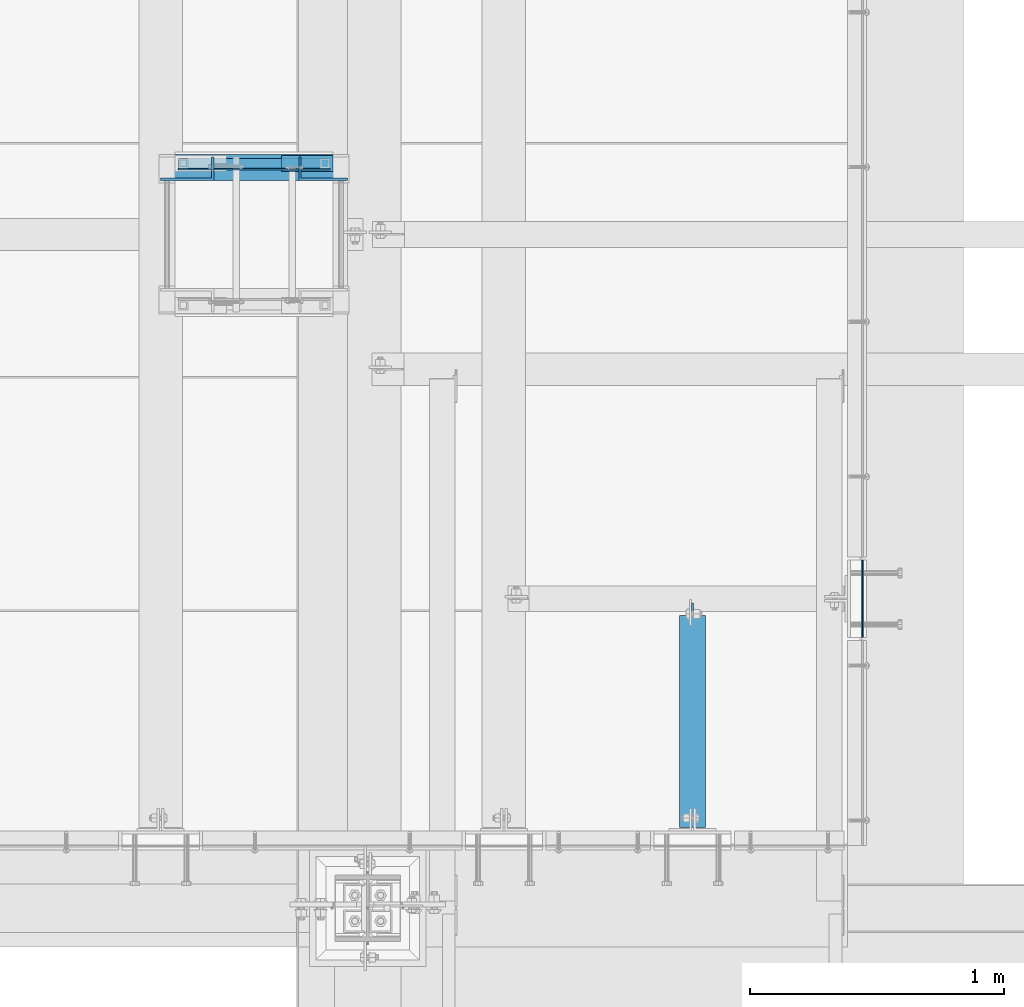
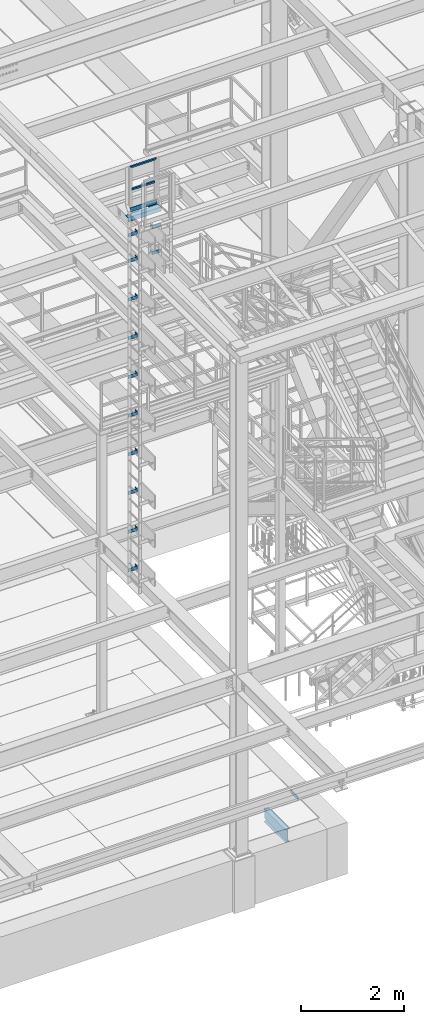
# One storey, part 2058 of 3843: 19 beams, 6 elements without a shape of their own.
"""IFC2X3 building model written with IfcOpenShell, lengths in millimetres."""

from ifc_helpers import new_model, si_unit, frame, origin_with_axes, place, context, subcontext, project, spatial, faceted_brep, material, type_object, element, aggregate, save


model = new_model("IFC2X3")

# Units and contexts
model_context = context("Model", 3, precision=1e-05, world=origin_with_axes())
body_context = subcontext(model_context, "Body", "Model", "MODEL_VIEW")
ifc_project = project(units=[si_unit("LENGTHUNIT", "METRE", prefix="MILLI"), si_unit("AREAUNIT", "SQUARE_METRE"), si_unit("VOLUMEUNIT", "CUBIC_METRE"), si_unit("MASSUNIT", "GRAM", prefix="KILO"), si_unit("TIMEUNIT", "SECOND"), si_unit("PLANEANGLEUNIT", "RADIAN"), si_unit("SOLIDANGLEUNIT", "STERADIAN"), si_unit("THERMODYNAMICTEMPERATUREUNIT", "DEGREE_CELSIUS"), si_unit("LUMINOUSINTENSITYUNIT", "LUMEN")], contexts=[model_context])

# Site, building, storey
site_placement = place(None, origin_with_axes())
site = spatial("IfcSite", under=ifc_project, at=site_placement, CompositionType="ELEMENT")
building_placement = place(site_placement, origin_with_axes())
building = spatial("IfcBuilding", under=site, at=building_placement, Name="Undefined", CompositionType="ELEMENT")
storey_placement = place(building_placement, origin_with_axes())
storey = spatial("IfcBuildingStorey", under=building, at=storey_placement, Name="Undefined", CompositionType="ELEMENT", Elevation=0.0)

# Assembly, beams
assembly_1_placement = place(storey_placement, origin_with_axes())
assembly_1 = element("IfcElementAssembly", 1, at=assembly_1_placement, inside=storey, Name="LADDER", AssemblyPlace="NOTDEFINED", PredefinedType="RIGID_FRAME")
ifc_material_1 = material(Name="STEEL/A36")
beam_type_1 = type_object("IfcBeamType", PredefinedType="NOTDEFINED")
beam_1_placement = place(assembly_1_placement, frame((48917.225012207, 17870.4875, 43021.25), z_axis=(0.0, 0.0, 1.0), x_axis=(-1.0, 0.0, 0.0)))
beam_1 = element("IfcBeam", 2, at=beam_1_placement, type_object=beam_type_1, material=ifc_material_1, Name="BENT_PLATE", context=body_context, shape_type="Brep", body=[
    faceted_brep([(0.0, -4.76250000000073, -38.0999999999985), (0.0, -4.76250000000073, 38.0999999999985), (0.0, 4.76250000000073, 38.0999999999985), (0.0, 4.76250000000073, -38.0999999999985), (192.087500000001, 4.76249999999345, 38.0999999999985), (192.087500000001, 4.76249999999345, -38.0999999999985), (182.562500000007, -4.762500000008, -38.0999999999985), (182.562500000007, -4.762500000008, 38.0999999999985), (192.087500000001, -87.3124999995016, 38.0999999999985), (192.087500000001, -87.3124999995016, -38.0999999999985), (182.562500000007, -87.3124999995016, 38.0999999999985), (182.562500000007, -87.3124999995016, -38.0999999999985)], [[[0, 1, 2, 3]], [[3, 2, 4, 5]], [[1, 0, 6, 7]], [[5, 4, 8, 9]], [[4, 2, 1, 7, 10, 8]], [[7, 6, 11, 10]], [[6, 0, 3, 5, 9, 11]], [[10, 11, 9, 8]]]),
])
beam_2_placement = place(assembly_1_placement, frame((48917.225012207, 17870.4875, 43630.85), z_axis=(0.0, 0.0, 1.0), x_axis=(-1.0, 0.0, 0.0)))
beam_2 = element("IfcBeam", 3, at=beam_2_placement, type_object=beam_type_1, material=ifc_material_1, Name="BENT_PLATE", context=body_context, shape_type="Brep", body=[
    faceted_brep([(0.0, -4.76250000000073, -38.0999999999985), (0.0, -4.76250000000073, 38.0999999999985), (0.0, 4.76250000000073, 38.0999999999985), (0.0, 4.76250000000073, -38.0999999999985), (192.087500000001, 4.76249999999345, 38.0999999999985), (192.087500000001, 4.76249999999345, -38.0999999999985), (182.562500000007, -4.762500000008, -38.0999999999985), (182.562500000007, -4.762500000008, 38.0999999999985), (192.087500000001, -87.3124999995016, 38.0999999999985), (192.087500000001, -87.3124999995016, -38.0999999999985), (182.562500000007, -87.3124999995016, 38.0999999999985), (182.562500000007, -87.3124999995016, -38.0999999999985)], [[[0, 1, 2, 3]], [[3, 2, 4, 5]], [[1, 0, 6, 7]], [[5, 4, 8, 9]], [[4, 2, 1, 7, 10, 8]], [[7, 6, 11, 10]], [[6, 0, 3, 5, 9, 11]], [[10, 11, 9, 8]]]),
])
aggregate(assembly_1, [beam_1, beam_2])

assembly_2_placement = place(storey_placement, origin_with_axes())
assembly_2 = element("IfcElementAssembly", 4, at=assembly_2_placement, inside=storey, Name="LADDER", AssemblyPlace="NOTDEFINED", PredefinedType="RIGID_FRAME")
beam_3_placement = place(assembly_2_placement, frame((48180.624987793, 17870.4875, 43630.85), z_axis=(0.0, 0.0, 1.0), x_axis=(1.0, 0.0, 0.0)))
beam_3 = element("IfcBeam", 5, at=beam_3_placement, type_object=beam_type_1, material=ifc_material_1, Name="BENT_PLATE", context=body_context, shape_type="Brep", body=[
    faceted_brep([(0.0, -4.76250000000073, -38.0999999999985), (0.0, -4.76250000000073, 38.0999999999985), (0.0, 4.76250000000073, 38.0999999999985), (0.0, 4.76250000000073, -38.0999999999985), (200.025000000009, 4.762500000008, 38.0999999999985), (200.025000000009, 4.762500000008, -38.0999999999985), (209.550000000003, -4.76249999999345, -38.0999999999985), (209.550000000003, -4.76249999999345, 38.0999999999985), (200.025000000009, 87.3124999995016, 38.0999999999985), (200.025000000009, 87.3124999995016, -38.0999999999985), (209.550000000003, 87.3124999995016, 38.0999999999985), (209.550000000003, 87.3124999995016, -38.0999999999985)], [[[0, 1, 2, 3]], [[3, 2, 4, 5]], [[1, 0, 6, 7]], [[5, 4, 8, 9]], [[4, 2, 1, 7, 10, 8]], [[7, 6, 11, 10]], [[6, 0, 3, 5, 9, 11]], [[10, 11, 9, 8]]]),
])
beam_4_placement = place(assembly_2_placement, frame((48180.624987793, 17870.4875, 43021.25), z_axis=(0.0, 0.0, 1.0), x_axis=(1.0, 0.0, 0.0)))
beam_4 = element("IfcBeam", 6, at=beam_4_placement, type_object=beam_type_1, material=ifc_material_1, Name="BENT_PLATE", context=body_context, shape_type="Brep", body=[
    faceted_brep([(0.0, -4.76250000000073, -38.0999999999985), (0.0, -4.76250000000073, 38.0999999999985), (0.0, 4.76250000000073, 38.0999999999985), (0.0, 4.76250000000073, -38.0999999999985), (200.025000000009, 4.762500000008, 38.0999999999985), (200.025000000009, 4.762500000008, -38.0999999999985), (209.550000000003, -4.76249999999345, -38.0999999999985), (209.550000000003, -4.76249999999345, 38.0999999999985), (200.025000000009, 87.3124999995016, 38.0999999999985), (200.025000000009, 87.3124999995016, -38.0999999999985), (209.550000000003, 87.3124999995016, 38.0999999999985), (209.550000000003, 87.3124999995016, -38.0999999999985)], [[[0, 1, 2, 3]], [[3, 2, 4, 5]], [[1, 0, 6, 7]], [[5, 4, 8, 9]], [[4, 2, 1, 7, 10, 8]], [[7, 6, 11, 10]], [[6, 0, 3, 5, 9, 11]], [[10, 11, 9, 8]]]),
])
beam_5_placement = place(assembly_2_placement, frame((48180.624987793, 17870.4875, 42106.85), z_axis=(0.0, 0.0, 1.0), x_axis=(1.0, 0.0, 0.0)))
beam_5 = element("IfcBeam", 7, at=beam_5_placement, type_object=beam_type_1, material=ifc_material_1, Name="BENT_PLATE", context=body_context, shape_type="Brep", body=[
    faceted_brep([(0.0, -4.76250000000073, -38.0999999999985), (0.0, -4.76250000000073, 38.0999999999985), (0.0, 4.76250000000073, 38.0999999999985), (0.0, 4.76250000000073, -38.0999999999985), (200.025000000009, 4.762500000008, 38.0999999999985), (200.025000000009, 4.762500000008, -38.0999999999985), (209.550000000003, -4.76249999999345, -38.0999999999985), (209.550000000003, -4.76249999999345, 38.0999999999985), (200.025000000009, 87.3124999995016, 38.0999999999985), (200.025000000009, 87.3124999995016, -38.0999999999985), (209.550000000003, 87.3124999995016, 38.0999999999985), (209.550000000003, 87.3124999995016, -38.0999999999985)], [[[0, 1, 2, 3]], [[3, 2, 4, 5]], [[1, 0, 6, 7]], [[5, 4, 8, 9]], [[4, 2, 1, 7, 10, 8]], [[7, 6, 11, 10]], [[6, 0, 3, 5, 9, 11]], [[10, 11, 9, 8]]]),
])
beam_6_placement = place(assembly_2_placement, frame((48180.624987793, 17870.4875, 41192.45), z_axis=(0.0, 0.0, 1.0), x_axis=(1.0, 0.0, 0.0)))
beam_6 = element("IfcBeam", 8, at=beam_6_placement, type_object=beam_type_1, material=ifc_material_1, Name="BENT_PLATE", context=body_context, shape_type="Brep", body=[
    faceted_brep([(0.0, -4.76250000000073, -38.0999999999985), (0.0, -4.76250000000073, 38.0999999999985), (0.0, 4.76250000000073, 38.0999999999985), (0.0, 4.76250000000073, -38.0999999999985), (200.025000000009, 4.762500000008, 38.0999999999985), (200.025000000009, 4.762500000008, -38.0999999999985), (209.550000000003, -4.76249999999345, -38.0999999999985), (209.550000000003, -4.76249999999345, 38.0999999999985), (200.025000000009, 87.3124999995016, 38.0999999999985), (200.025000000009, 87.3124999995016, -38.0999999999985), (209.550000000003, 87.3124999995016, 38.0999999999985), (209.550000000003, 87.3124999995016, -38.0999999999985)], [[[0, 1, 2, 3]], [[3, 2, 4, 5]], [[1, 0, 6, 7]], [[5, 4, 8, 9]], [[4, 2, 1, 7, 10, 8]], [[7, 6, 11, 10]], [[6, 0, 3, 5, 9, 11]], [[10, 11, 9, 8]]]),
])
beam_7_placement = place(assembly_2_placement, frame((48180.624987793, 17870.4875, 40278.05), z_axis=(0.0, 0.0, 1.0), x_axis=(1.0, 0.0, 0.0)))
beam_7 = element("IfcBeam", 9, at=beam_7_placement, type_object=beam_type_1, material=ifc_material_1, Name="BENT_PLATE", context=body_context, shape_type="Brep", body=[
    faceted_brep([(0.0, -4.76250000000073, -38.0999999999985), (0.0, -4.76250000000073, 38.0999999999985), (0.0, 4.76250000000073, 38.0999999999985), (0.0, 4.76250000000073, -38.0999999999985), (200.025000000009, 4.762500000008, 38.0999999999985), (200.025000000009, 4.762500000008, -38.0999999999985), (209.550000000003, -4.76249999999345, -38.0999999999985), (209.550000000003, -4.76249999999345, 38.0999999999985), (200.025000000009, 87.3124999995016, 38.0999999999985), (200.025000000009, 87.3124999995016, -38.0999999999985), (209.550000000003, 87.3124999995016, 38.0999999999985), (209.550000000003, 87.3124999995016, -38.0999999999985)], [[[0, 1, 2, 3]], [[3, 2, 4, 5]], [[1, 0, 6, 7]], [[5, 4, 8, 9]], [[4, 2, 1, 7, 10, 8]], [[7, 6, 11, 10]], [[6, 0, 3, 5, 9, 11]], [[10, 11, 9, 8]]]),
])
beam_8_placement = place(assembly_2_placement, frame((48180.624987793, 17870.4875, 39363.65), z_axis=(0.0, 0.0, 1.0), x_axis=(1.0, 0.0, 0.0)))
beam_8 = element("IfcBeam", 10, at=beam_8_placement, type_object=beam_type_1, material=ifc_material_1, Name="BENT_PLATE", context=body_context, shape_type="Brep", body=[
    faceted_brep([(0.0, -4.76250000000073, -38.0999999999985), (0.0, -4.76250000000073, 38.0999999999985), (0.0, 4.76250000000073, 38.0999999999985), (0.0, 4.76250000000073, -38.0999999999985), (200.025000000009, 4.762500000008, 38.0999999999985), (200.025000000009, 4.762500000008, -38.0999999999985), (209.550000000003, -4.76249999999345, -38.0999999999985), (209.550000000003, -4.76249999999345, 38.0999999999985), (200.025000000009, 87.3124999995016, 38.0999999999985), (200.025000000009, 87.3124999995016, -38.0999999999985), (209.550000000003, 87.3124999995016, 38.0999999999985), (209.550000000003, 87.3124999995016, -38.0999999999985)], [[[0, 1, 2, 3]], [[3, 2, 4, 5]], [[1, 0, 6, 7]], [[5, 4, 8, 9]], [[4, 2, 1, 7, 10, 8]], [[7, 6, 11, 10]], [[6, 0, 3, 5, 9, 11]], [[10, 11, 9, 8]]]),
])
beam_9_placement = place(assembly_2_placement, frame((48180.624987793, 17870.4875, 38449.25), z_axis=(0.0, 0.0, 1.0), x_axis=(1.0, 0.0, 0.0)))
beam_9 = element("IfcBeam", 11, at=beam_9_placement, type_object=beam_type_1, material=ifc_material_1, Name="BENT_PLATE", context=body_context, shape_type="Brep", body=[
    faceted_brep([(0.0, -4.76250000000073, -38.0999999999985), (0.0, -4.76250000000073, 38.0999999999985), (0.0, 4.76250000000073, 38.0999999999985), (0.0, 4.76250000000073, -38.0999999999985), (200.025000000009, 4.762500000008, 38.0999999999985), (200.025000000009, 4.762500000008, -38.0999999999985), (209.550000000003, -4.76249999999345, -38.0999999999985), (209.550000000003, -4.76249999999345, 38.0999999999985), (200.025000000009, 87.3124999995016, 38.0999999999985), (200.025000000009, 87.3124999995016, -38.0999999999985), (209.550000000003, 87.3124999995016, 38.0999999999985), (209.550000000003, 87.3124999995016, -38.0999999999985)], [[[0, 1, 2, 3]], [[3, 2, 4, 5]], [[1, 0, 6, 7]], [[5, 4, 8, 9]], [[4, 2, 1, 7, 10, 8]], [[7, 6, 11, 10]], [[6, 0, 3, 5, 9, 11]], [[10, 11, 9, 8]]]),
])
beam_10_placement = place(assembly_2_placement, frame((48180.624987793, 17870.4875, 37534.85), z_axis=(0.0, 0.0, 1.0), x_axis=(1.0, 0.0, 0.0)))
beam_10 = element("IfcBeam", 12, at=beam_10_placement, type_object=beam_type_1, material=ifc_material_1, Name="BENT_PLATE", context=body_context, shape_type="Brep", body=[
    faceted_brep([(0.0, -4.76250000000073, -38.0999999999985), (0.0, -4.76250000000073, 38.0999999999985), (0.0, 4.76250000000073, 38.0999999999985), (0.0, 4.76250000000073, -38.0999999999985), (200.025000000009, 4.762500000008, 38.0999999999985), (200.025000000009, 4.762500000008, -38.0999999999985), (209.550000000003, -4.76249999999345, -38.0999999999985), (209.550000000003, -4.76249999999345, 38.0999999999985), (200.025000000009, 87.3124999995016, 38.0999999999985), (200.025000000009, 87.3124999995016, -38.0999999999985), (209.550000000003, 87.3124999995016, 38.0999999999985), (209.550000000003, 87.3124999995016, -38.0999999999985)], [[[0, 1, 2, 3]], [[3, 2, 4, 5]], [[1, 0, 6, 7]], [[5, 4, 8, 9]], [[4, 2, 1, 7, 10, 8]], [[7, 6, 11, 10]], [[6, 0, 3, 5, 9, 11]], [[10, 11, 9, 8]]]),
])
beam_11_placement = place(assembly_2_placement, frame((48180.624987793, 17870.4875, 36620.45), z_axis=(0.0, 0.0, 1.0), x_axis=(1.0, 0.0, 0.0)))
beam_11 = element("IfcBeam", 13, at=beam_11_placement, type_object=beam_type_1, material=ifc_material_1, Name="BENT_PLATE", context=body_context, shape_type="Brep", body=[
    faceted_brep([(0.0, -4.76250000000073, -38.0999999999985), (0.0, -4.76250000000073, 38.0999999999985), (0.0, 4.76250000000073, 38.0999999999985), (0.0, 4.76250000000073, -38.0999999999985), (200.025000000009, 4.762500000008, 38.0999999999985), (200.025000000009, 4.762500000008, -38.0999999999985), (209.550000000003, -4.76249999999345, -38.0999999999985), (209.550000000003, -4.76249999999345, 38.0999999999985), (200.025000000009, 87.3124999995016, 38.0999999999985), (200.025000000009, 87.3124999995016, -38.0999999999985), (209.550000000003, 87.3124999995016, 38.0999999999985), (209.550000000003, 87.3124999995016, -38.0999999999985)], [[[0, 1, 2, 3]], [[3, 2, 4, 5]], [[1, 0, 6, 7]], [[5, 4, 8, 9]], [[4, 2, 1, 7, 10, 8]], [[7, 6, 11, 10]], [[6, 0, 3, 5, 9, 11]], [[10, 11, 9, 8]]]),
])
beam_12_placement = place(assembly_2_placement, frame((48180.624987793, 17870.4875, 35706.05), z_axis=(0.0, 0.0, 1.0), x_axis=(1.0, 0.0, 0.0)))
beam_12 = element("IfcBeam", 14, at=beam_12_placement, type_object=beam_type_1, material=ifc_material_1, Name="BENT_PLATE", context=body_context, shape_type="Brep", body=[
    faceted_brep([(0.0, -4.76250000000073, -38.0999999999985), (0.0, -4.76250000000073, 38.0999999999985), (0.0, 4.76250000000073, 38.0999999999985), (0.0, 4.76250000000073, -38.0999999999985), (200.025000000009, 4.762500000008, 38.0999999999985), (200.025000000009, 4.762500000008, -38.0999999999985), (209.550000000003, -4.76249999999345, -38.0999999999985), (209.550000000003, -4.76249999999345, 38.0999999999985), (200.025000000009, 87.3124999995016, 38.0999999999985), (200.025000000009, 87.3124999995016, -38.0999999999985), (209.550000000003, 87.3124999995016, 38.0999999999985), (209.550000000003, 87.3124999995016, -38.0999999999985)], [[[0, 1, 2, 3]], [[3, 2, 4, 5]], [[1, 0, 6, 7]], [[5, 4, 8, 9]], [[4, 2, 1, 7, 10, 8]], [[7, 6, 11, 10]], [[6, 0, 3, 5, 9, 11]], [[10, 11, 9, 8]]]),
])
aggregate(assembly_2, [beam_3, beam_4, beam_5, beam_6, beam_7, beam_8, beam_9, beam_10, beam_11, beam_12])

assembly_3_placement = place(storey_placement, origin_with_axes())
assembly_3 = element("IfcElementAssembly", 15, at=assembly_3_placement, inside=storey, Name="RAIL", AssemblyPlace="NOTDEFINED", PredefinedType="RIGID_FRAME")
ifc_material_2 = material()
beam_type_2 = type_object("IfcBeamType", Name="HSS1-1/2X1-1/2X1/4", PredefinedType="NOTDEFINED")
beam_13_placement = place(assembly_3_placement, frame((48269.524987793, 17932.4, 44646.85), z_axis=(0.0, -1.0, 0.0), x_axis=(1.0, 0.0, 0.0)))
beam_13 = element("IfcBeam", 16, at=beam_13_placement, type_object=beam_type_2, material=ifc_material_2, Name="RAIL", ObjectType="HSS1-1/2X1-1/2X1/4", context=body_context, shape_type="Brep", body=[
    faceted_brep([(19.0499992350015, 12.6999993299978, -12.6999993299978), (19.0499992350015, -12.6999993299978, -12.6999993299978), (539.75001373695, -12.6999993299978, -12.6999993300014), (539.75001373695, 12.6999993299978, -12.6999993300014), (19.0499992350015, -12.6999993299978, 12.6999993299978), (539.75001373695, -12.6999993299978, 12.6999993300014), (19.0499992350015, 12.6999993299978, 12.6999993299978), (539.75001373695, 12.6999993299978, 12.6999993300014), (19.0499992350015, 19.0499992350015, -19.0499992350015), (19.0499992350015, 19.0499992350015, 19.0499992350015), (539.75001373695, 19.0499992350015, 19.0499992350015), (539.75001373695, 19.0499992350015, -19.0499992350015), (19.0499992350015, -19.0499992350015, 19.0499992350015), (539.75001373695, -19.0499992350015, 19.0499992350015), (19.0499992350015, -19.0499992350015, -19.0499992350015), (539.75001373695, -19.0499992350015, -19.0499992350015)], [[[0, 1, 2, 3]], [[1, 4, 5, 2]], [[4, 6, 7, 5]], [[6, 0, 3, 7]], [[8, 9, 10, 11]], [[9, 12, 13, 10]], [[12, 14, 15, 13]], [[14, 8, 11, 15]], [[13, 15, 11, 10], [5, 7, 3, 2]], [[14, 12, 9, 8], [6, 4, 1, 0]]]),
])
beam_14_placement = place(assembly_3_placement, frame((48269.524987793, 17932.4, 45180.25), z_axis=(0.0, -1.0, 0.0), x_axis=(1.0, 0.0, 0.0)))
beam_14 = element("IfcBeam", 17, at=beam_14_placement, type_object=beam_type_2, material=ifc_material_2, Name="RAIL", ObjectType="HSS1-1/2X1-1/2X1/4", context=body_context, shape_type="Brep", body=[
    faceted_brep([(-12.6999993309546, 12.6999993299978, -12.6999993299978), (12.6999993300014, -12.6999993299978, -12.6999993300014), (546.099999317878, -12.6999993300014, -12.6999993299978), (571.500012302, 12.6999993299978, -12.6999993300014), (12.6999993290483, -12.6999993299978, 12.6999993299978), (546.100013642004, -12.6999993299978, 12.6999993300014), (-12.6999993300014, 12.6999993299978, 12.6999993300014), (571.500012302, 12.6999993299978, 12.6999993300014), (-19.0499992359546, 19.0499992350015, -19.0499992350015), (-19.0499992350015, 19.0499992350015, 19.0499992350015), (577.850012207004, 19.0499992350015, 19.0499992350015), (577.850012207004, 19.0499992350015, -19.0499992350015), (19.0499992350015, -19.0499992350015, 19.0499992350015), (539.75001373695, -19.0499992350015, 19.0499992350015), (19.0499992350015, -19.0499992350015, -19.0499992350015), (539.75001373695, -19.0499992350015, -19.0499992350015)], [[[0, 1, 2, 3]], [[1, 4, 5, 2]], [[4, 6, 7, 5]], [[6, 0, 3, 7]], [[8, 9, 10, 11]], [[9, 12, 13, 10]], [[12, 14, 15, 13]], [[14, 8, 11, 15]], [[13, 15, 11, 10], [5, 7, 3, 2]], [[14, 12, 9, 8], [6, 4, 1, 0]]]),
])

# Assembly, beam
assembly_4_placement = place(storey_placement, origin_with_axes())
assembly_4 = element("IfcElementAssembly", 18, at=assembly_4_placement, inside=storey, Name="EMBED PLATE", AssemblyPlace="NOTDEFINED", PredefinedType="RIGID_FRAME")
beam_type_3 = type_object("IfcBeamType", PredefinedType="NOTDEFINED")
beam_15_placement = place(assembly_4_placement, frame((50946.0331775832, 16370.3, 30441.9), z_axis=(0.0, 0.0, 1.0), x_axis=(0.0, -1.0, 0.0)))
beam_15 = element("IfcBeam", 19, at=beam_15_placement, type_object=beam_type_3, material=ifc_material_1, Name="PLATE", context=body_context, shape_type="Brep", body=[
    faceted_brep([(0.0, 3.17500000000291, -38.0999999999985), (0.0, 3.17500000000291, 38.0999999999985), (304.800000000003, 3.17499999999927, 38.0999999999985), (304.800000000003, 3.17499999999927, -38.0999999999985), (0.0, -3.17500000000291, 38.0999999999985), (304.800000000003, -3.17499999999927, 38.0999999999985), (0.0, -3.17500000000291, -38.0999999999985), (304.800000000003, -3.17499999999927, -38.0999999999985)], [[[0, 1, 2, 3]], [[1, 4, 5, 2]], [[4, 6, 7, 5]], [[6, 0, 3, 7]], [[5, 7, 3, 2]], [[6, 4, 1, 0]]]),
])
aggregate(assembly_4, [beam_15])

# Beam
beam_type_4 = type_object("IfcBeamType", PredefinedType="NOTDEFINED")
beam_16_placement = place(assembly_3_placement, frame((48860.0749998093, 17932.4, 44116.625), z_axis=(0.0, -1.0, 0.0), x_axis=(-1.0, 0.0, 0.0)))
beam_16 = element("IfcBeam", 20, at=beam_16_placement, type_object=beam_type_4, material=ifc_material_1, context=body_context, shape_type="Brep", body=[
    faceted_brep([(0.0, 3.17500000000291, -31.75), (0.0, 3.17500000000291, 31.75), (203.199998088516, 3.17500000000291, 31.75), (203.199998088516, 3.17500000000291, -31.75), (0.0, -3.17500000000291, 31.75), (203.199998088516, -3.17500000000291, 31.75), (0.0, -3.17500000000291, -31.75), (203.199998088516, -3.17500000000291, -31.75)], [[[0, 1, 2, 3]], [[1, 4, 5, 2]], [[4, 6, 7, 5]], [[6, 0, 3, 7]], [[5, 7, 3, 2]], [[6, 4, 1, 0]]]),
])

beam_type_5 = type_object("IfcBeamType", PredefinedType="NOTDEFINED")
beam_17_placement = place(assembly_3_placement, frame((48250.4749903701, 17910.1750007651, 44183.3), z_axis=(0.0, 0.0, 1.0), x_axis=(1.0, 0.0, 0.0)))
beam_17 = element("IfcBeam", 21, at=beam_17_placement, type_object=beam_type_5, material=ifc_material_1, Name="TOE_PLATE", context=body_context, shape_type="Brep", body=[
    faceted_brep([(0.0, 3.17500000000291, -50.8000000000029), (0.0, 3.17500000000291, 50.8000000000029), (596.900010681646, 3.17499999999927, 50.8000000000029), (596.900010681646, 3.17499999999927, -50.8000000000029), (0.0, -3.17500000000291, 50.8000000000029), (596.900010681646, -3.17499999999927, 50.8000000000029), (0.0, -3.17500000000291, -50.8000000000029), (596.900010681646, -3.17499999999927, -50.8000000000029)], [[[0, 1, 2, 3]], [[1, 4, 5, 2]], [[4, 6, 7, 5]], [[6, 0, 3, 7]], [[5, 7, 3, 2]], [[6, 4, 1, 0]]]),
])

aggregate(assembly_3, [beam_17, beam_16, beam_13, beam_14])

# Assembly, beam
assembly_5_placement = place(storey_placement, origin_with_axes())
assembly_5 = element("IfcElementAssembly", 22, at=assembly_5_placement, inside=storey, Name="ANGLE", AssemblyPlace="NOTDEFINED", PredefinedType="RIGID_FRAME")
beam_type_6 = type_object("IfcBeamType", Name="L4X4X3/8", PredefinedType="NOTDEFINED")
beam_18_placement = place(assembly_5_placement, frame((48180.624987793, 17916.525, 43999.15), z_axis=(0.0, 0.0, -1.0), x_axis=(1.0, 0.0, 0.0)))
beam_18 = element("IfcBeam", 23, at=beam_18_placement, type_object=beam_type_6, material=ifc_material_1, Name="ANGLE", ObjectType="L4X4X3/8", context=body_context, shape_type="Brep", body=[
    faceted_brep([(0.0, 50.8000000000029, -50.8000000000029), (0.0, 50.8000000000029, 50.8000000000029), (739.775012207028, 50.7999999999993, 50.8000000000029), (739.775012207028, 50.7999999999993, -50.8000000000029), (0.0, 41.2750000000015, 50.8000000000029), (739.775012207028, 41.2750000000015, 50.8000000000029), (0.0, 41.2749999999942, -41.2750000000015), (739.775012207028, 41.2750000000015, -41.2750000000015), (0.0, -50.8000000000029, -41.2750000000015), (739.775012207028, -50.7999999999993, -41.2750000000015), (0.0, -50.8000000000029, -50.8000000000029), (739.775012207028, -50.7999999999993, -50.8000000000029)], [[[0, 1, 2, 3]], [[1, 4, 5, 2]], [[4, 6, 7, 5]], [[6, 8, 9, 7]], [[8, 10, 11, 9]], [[10, 0, 3, 11]], [[5, 7, 9, 11, 3, 2]], [[10, 8, 6, 4, 1, 0]]]),
])
aggregate(assembly_5, [beam_18])

assembly_6_placement = place(storey_placement, origin_with_axes())
assembly_6 = element("IfcElementAssembly", 24, at=assembly_6_placement, inside=storey, Name="BEAM", AssemblyPlace="NOTDEFINED", PredefinedType="RIGID_FRAME")
ifc_material_3 = material(Name="STEEL/A992")
beam_type_7 = type_object("IfcBeamType", Name="W12X16", PredefinedType="NOTDEFINED")
beam_19_placement = place(assembly_6_placement, frame((50276.125, 15303.5, 30251.4), z_axis=(0.0, 0.0, 1.0), x_axis=(0.0, 1.0, 0.0)))
beam_19 = element("IfcBeam", 25, at=beam_19_placement, type_object=beam_type_7, material=ifc_material_3, Name="BEAM", ObjectType="W12X16", context=body_context, shape_type="Brep", body=[
    faceted_brep([(847.725000000002, -3.17500000000291, -146.049999999999), (847.725000000002, -50.8000000000029, -146.049999999999), (847.725000000002, -50.8000000000029, -152.400000000001), (847.725000000002, 50.8000000000029, -152.400000000001), (847.725000000002, 50.8000000000029, -146.049999999999), (847.725000000002, 3.17500000000291, -146.049999999999), (847.725000000002, 3.17500000000291, -139.699999809258), (847.725000000002, -3.17500000000291, -139.699999809258), (848.69172992259, 3.17500000000291, -134.839920291211), (848.69172992259, -3.17500000000291, -134.839920291211), (851.444743823067, 3.17500000000291, -130.719743823058), (851.444743823067, -3.17500000000291, -130.719743823058), (855.564920291221, 3.17500000000291, -127.96672992258), (855.564920291221, -3.17500000000291, -127.96672992258), (860.424999809267, 3.17500000000291, -126.999999999993), (860.424999809267, -3.17500000000291, -126.999999999993), (898.525000000001, -3.17500000000291, -126.999999999993), (898.525000000001, 3.17500000000291, -126.999999999993), (12.7000000064072, 3.17500000014843, 146.04999999977), (12.7000030517593, 50.7999999999993, 146.049999999999), (847.725000000002, 50.8000000000029, 146.049999999999), (847.725000000002, 3.17500000000291, 146.049999999999), (12.7000030517593, -50.7999999999993, -152.400000000001), (12.7000030517593, -50.7999999999993, -146.049999999999), (12.7000000064072, -3.17500000016298, -146.049999999763), (12.7000000064072, -3.17499999987194, 146.049999999777), (12.7000030517593, -50.7999999999993, 146.049999999999), (12.7000030517593, -50.7999999999993, 152.400000000001), (12.7000030517593, 50.7999999999993, 152.400000000001), (12.7000000064072, 3.17499999985739, -146.049999999763), (12.7000030517593, 50.7999999999993, -146.049999999999), (12.7000030517593, 50.7999999999993, -152.400000000001), (847.725000000002, -3.17500000000291, 146.049999999999), (847.725000000002, -50.8000000000029, 146.049999999999), (847.725000000002, -50.8000000000029, 152.400000000001), (847.725000000002, 50.8000000000029, 152.400000000001), (847.725000000002, -3.17500000000291, 139.699999809272), (847.725000000002, 3.17500000000291, 139.699999809272), (848.69172992259, -3.17500000000291, 134.839920291226), (848.69172992259, 3.17500000000291, 134.839920291226), (851.444743823067, -3.17500000000291, 130.719743823072), (851.444743823067, 3.17500000000291, 130.719743823072), (855.564920291221, -3.17500000000291, 127.966729922595), (855.564920291221, 3.17500000000291, 127.966729922595), (860.424999809267, -3.17500000000291, 127.000000000007), (860.424999809267, 3.17500000000291, 127.000000000007), (898.525000000001, -3.17500000000291, 127.000000000007), (898.525000000001, 3.17500000000291, 127.000000000007), (898.525000000001, 3.17500000000291, -116.299999999999), (898.525000000001, 3.17500000000291, 114.299999999999)], [[[0, 1, 2, 3, 4, 5, 6, 7]], [[7, 6, 8, 9]], [[9, 8, 10, 11]], [[11, 10, 12, 13]], [[13, 12, 14, 15]], [[16, 15, 14, 17]], [[18, 19, 20, 21]], [[22, 23, 24, 25, 26, 27, 28, 19, 18, 29, 30, 31]], [[26, 25, 32, 33]], [[27, 26, 33, 34]], [[28, 27, 34, 35]], [[19, 28, 35, 20]], [[34, 33, 32, 36, 37, 21, 20, 35]], [[38, 39, 37, 36]], [[40, 41, 39, 38]], [[42, 43, 41, 40]], [[44, 45, 43, 42]], [[46, 47, 45, 44]], [[48, 49, 47, 46, 16, 17]], [[12, 10, 8, 6, 5, 29, 18, 21, 37, 39, 41, 43, 45, 47, 49, 48, 17, 14]], [[30, 29, 5, 4]], [[31, 30, 4, 3]], [[22, 31, 3, 2]], [[23, 22, 2, 1]], [[24, 23, 1, 0]], [[46, 44, 42, 40, 38, 36, 32, 25, 24, 0, 7, 9, 11, 13, 15, 16]]]),
])
aggregate(assembly_6, [beam_19])

save(model, "model.ifc")
